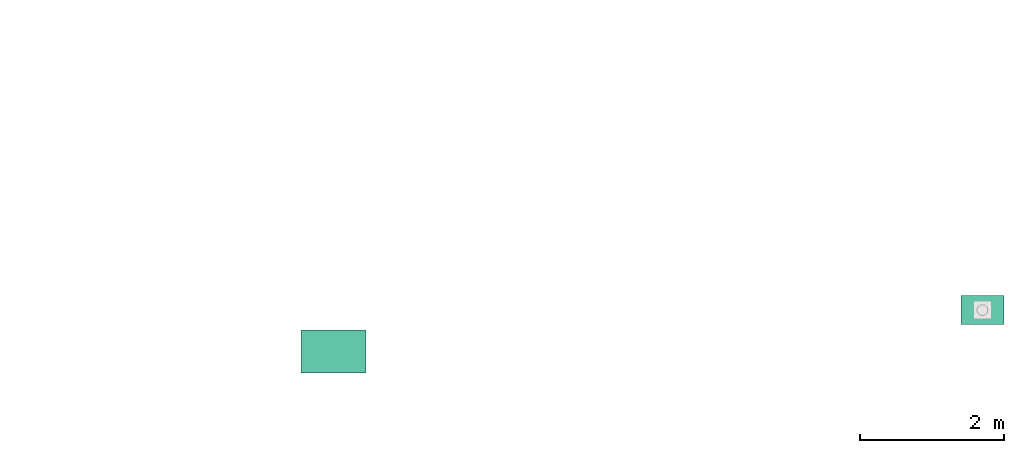
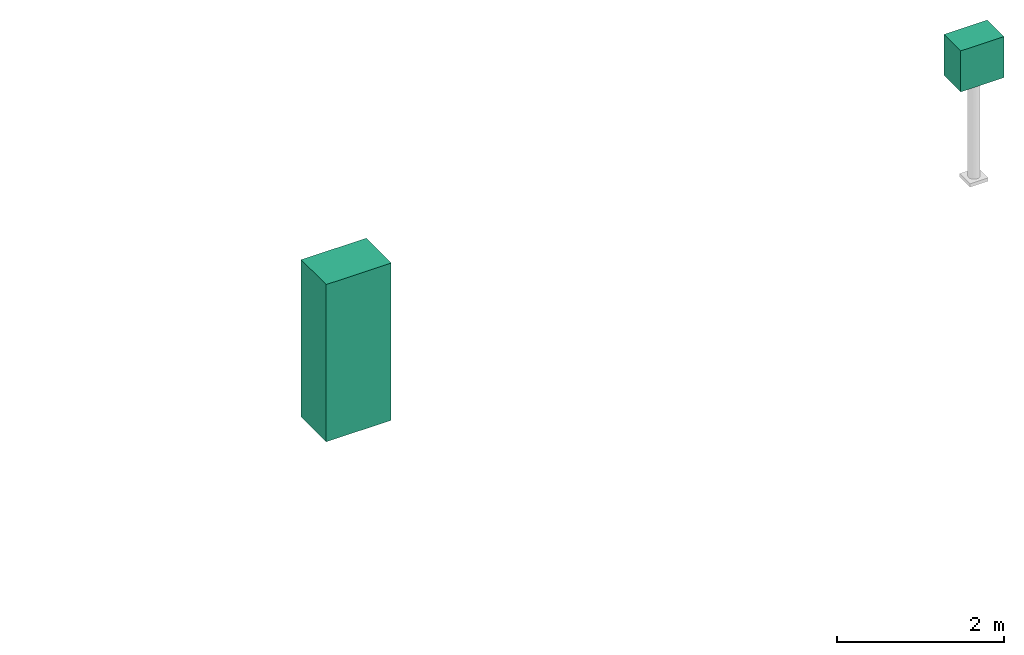
# One storey, part 2 of 6: 2 electric distribution points.
"""IFC2X3 building model written with IfcOpenShell, lengths in millimetres."""

from ifc_helpers import new_model, entity, si_unit, converted_unit, direction, frame, origin_with_axes, origin_2d_with_axis, place, context, project, spatial, rectangle, extrude, source, transform, mapped, element, save


model = new_model("IFC2X3")

# Units and contexts
model_context = context("Model", 3, precision=1e-05, world=origin_with_axes(), true_north=direction((0.0, 1.0)))
ifc_project = project(units=[si_unit("LENGTHUNIT", "METRE", prefix="MILLI"), si_unit("AREAUNIT", "SQUARE_METRE"), si_unit("VOLUMEUNIT", "CUBIC_METRE"), converted_unit("PLANEANGLEUNIT", "DEGREE", entity("IfcPlaneAngleMeasure", 0.017453293), si_unit("PLANEANGLEUNIT", "RADIAN"), dimensions=[0, 0, 0, 0, 0, 0, 0]), si_unit("SOLIDANGLEUNIT", "STERADIAN"), si_unit("MASSUNIT", "GRAM"), si_unit("TIMEUNIT", "SECOND"), si_unit("THERMODYNAMICTEMPERATUREUNIT", "DEGREE_CELSIUS"), si_unit("LUMINOUSINTENSITYUNIT", "LUMEN")], contexts=[model_context])

# Site, building, storey
site_placement = place(None, origin_with_axes())
site = spatial("IfcSite", under=ifc_project, at=site_placement, CompositionType="ELEMENT")
building_placement = place(site_placement, origin_with_axes())
building = spatial("IfcBuilding", under=site, at=building_placement, Name="Default Building", CompositionType="ELEMENT")
storey_placement = place(building_placement, origin_with_axes())
storey = spatial("IfcBuildingStorey", under=building, at=storey_placement, Name="1FL", CompositionType="ELEMENT", Elevation=0.0)

# Electric distribution points
shared_shape_1 = source(origin_with_axes(), model_context, "Body", "SweptSolid", [
    extrude(rectangle(XDim=900.0, YDim=600.0, at=origin_2d_with_axis()), frame((0.0, -300.0, 0.0), z_axis=(0.0, -2.44921270764475e-16, 1.0), x_axis=(1.0, 0.0, 0.0)), (0.0, 0.0, 1.0), 2300.0),
])
electric_distribution_point_1_placement = place(storey_placement, frame((47368.788147, 5154.367828, 0.0), z_axis=(0.0, 0.0, 1.0), x_axis=(1.0, 0.0, 0.0)))
element("IfcElectricDistributionPoint", 1, at=electric_distribution_point_1_placement, inside=storey, DistributionPointFunction="NOTDEFINED", context=model_context, shape_type="MappedRepresentation", body=[
    mapped(shared_shape_1, transform((0.0, 0.0, 0.0))),
])
shared_shape_2 = source(origin_with_axes(), model_context, "Body", "SweptSolid", [
    extrude(rectangle(XDim=600.0, YDim=400.0, at=origin_2d_with_axis()), frame((0.0, -200.0, 0.0), z_axis=(0.0, -2.44921270764475e-16, 1.0), x_axis=(1.0, 0.0, 0.0)), (0.0, 0.0, 1.0), 600.0),
])
electric_distribution_point_2_placement = place(storey_placement, frame((56383.485413, 5627.542877, 1500.0), z_axis=(0.0, 0.0, 1.0), x_axis=(1.0, 0.0, 0.0)))
element("IfcElectricDistributionPoint", 2, at=electric_distribution_point_2_placement, inside=storey, DistributionPointFunction="NOTDEFINED", context=model_context, shape_type="MappedRepresentation", body=[
    mapped(shared_shape_2, transform((0.0, 0.0, 0.0))),
])

save(model, "model.ifc")
